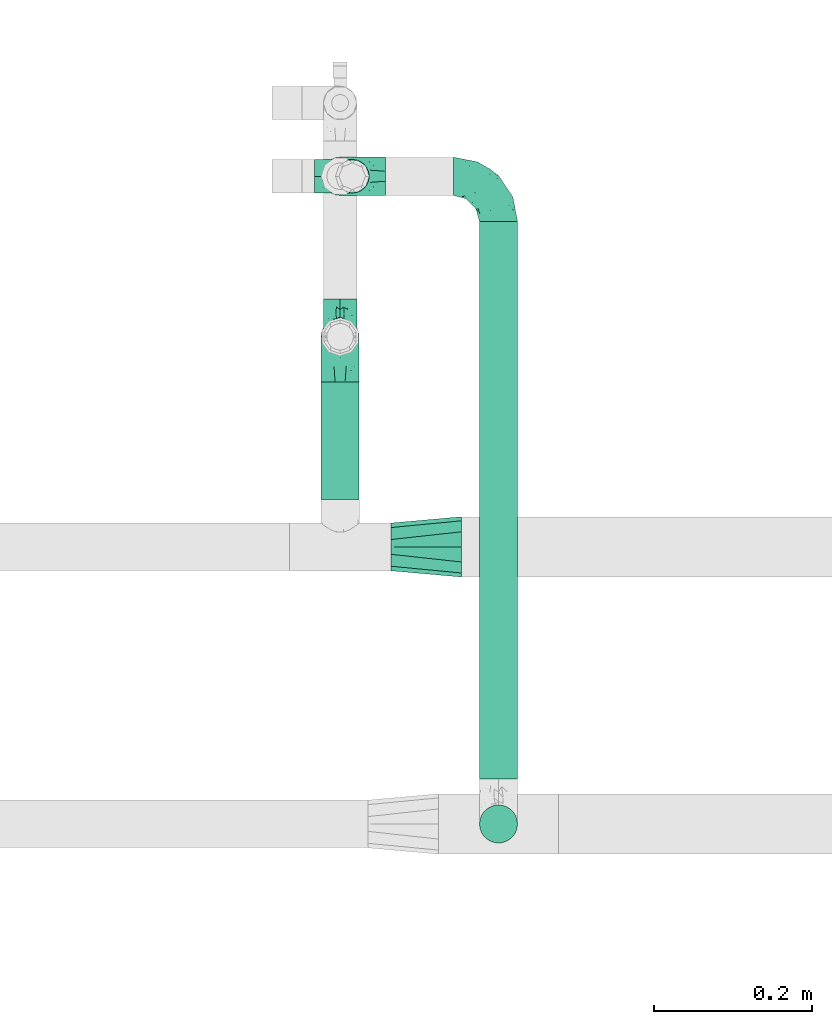
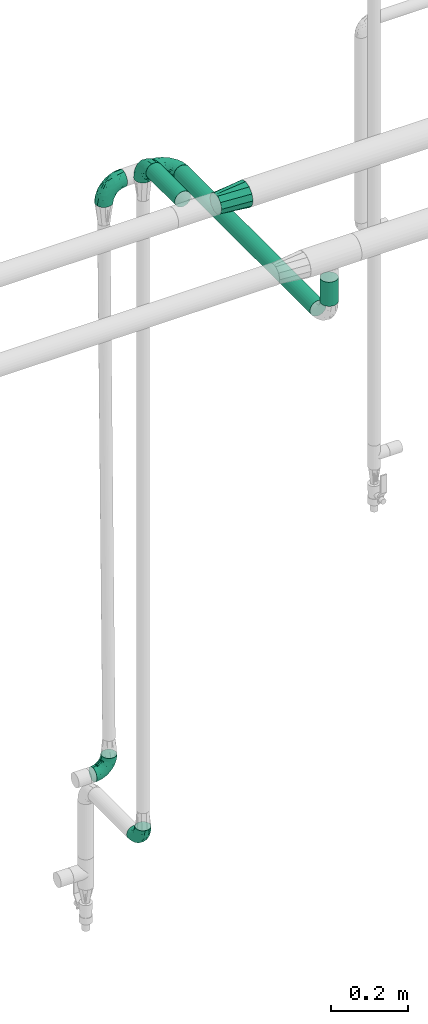
# One storey, part 565 of 824: 6 flow fittings, 3 flow segments.
"""IFC2X3 building model written with IfcOpenShell, lengths in millimetres."""

from ifc_helpers import new_model, entity, si_unit, converted_unit, derived_unit, direction, frame, origin, origin_2d_with_axis, place, context, subcontext, project, spatial, circle, extrude, faceted_brep, source, transform, mapped, material, type_object, type_shapes, element, save


model = new_model("IFC2X3")

# Units and contexts
model_context = context("Model", 3, precision=0.01, world=origin(), true_north=direction((6.12303176911189e-17, 1.0)))
body_context = subcontext(model_context, "Body", "Model", "MODEL_VIEW")
ifc_project = project(units=[si_unit("LENGTHUNIT", "METRE", prefix="MILLI"), si_unit("AREAUNIT", "SQUARE_METRE"), si_unit("VOLUMEUNIT", "CUBIC_METRE"), converted_unit("PLANEANGLEUNIT", "DEGREE", entity("IfcRatioMeasure", 0.0174532925199433), si_unit("PLANEANGLEUNIT", "RADIAN"), dimensions=[0, 0, 0, 0, 0, 0, 0]), si_unit("MASSUNIT", "GRAM", prefix="KILO"), derived_unit("MASSDENSITYUNIT", [(si_unit("MASSUNIT", "GRAM", prefix="KILO"), 1), (si_unit("LENGTHUNIT", "METRE"), -3)]), derived_unit("MOMENTOFINERTIAUNIT", [(si_unit("LENGTHUNIT", "METRE"), 4)]), si_unit("TIMEUNIT", "SECOND"), si_unit("FREQUENCYUNIT", "HERTZ"), si_unit("THERMODYNAMICTEMPERATUREUNIT", "DEGREE_CELSIUS"), derived_unit("THERMALTRANSMITTANCEUNIT", [(si_unit("MASSUNIT", "GRAM", prefix="KILO"), 1), (si_unit("THERMODYNAMICTEMPERATUREUNIT", "KELVIN"), -1), (si_unit("TIMEUNIT", "SECOND"), -3)]), derived_unit("VOLUMETRICFLOWRATEUNIT", [(si_unit("LENGTHUNIT", "METRE"), 3), (si_unit("TIMEUNIT", "SECOND"), -1)]), derived_unit("MASSFLOWRATEUNIT", [(si_unit("MASSUNIT", "GRAM", prefix="KILO"), 1), (si_unit("TIMEUNIT", "SECOND"), -1)]), derived_unit("ROTATIONALFREQUENCYUNIT", [(si_unit("TIMEUNIT", "SECOND"), -1)]), si_unit("ELECTRICCURRENTUNIT", "AMPERE"), si_unit("ELECTRICVOLTAGEUNIT", "VOLT"), si_unit("POWERUNIT", "WATT"), si_unit("FORCEUNIT", "NEWTON", prefix="KILO"), si_unit("ILLUMINANCEUNIT", "LUX"), si_unit("LUMINOUSFLUXUNIT", "LUMEN"), si_unit("LUMINOUSINTENSITYUNIT", "CANDELA"), derived_unit("USERDEFINED", [(si_unit("MASSUNIT", "GRAM", prefix="KILO"), -1), (si_unit("LENGTHUNIT", "METRE"), -2), (si_unit("TIMEUNIT", "SECOND"), 3), (si_unit("LUMINOUSFLUXUNIT", "LUMEN"), 1)]), derived_unit("LINEARVELOCITYUNIT", [(si_unit("LENGTHUNIT", "METRE"), 1), (si_unit("TIMEUNIT", "SECOND"), -1)]), si_unit("PRESSUREUNIT", "PASCAL"), derived_unit("USERDEFINED", [(si_unit("LENGTHUNIT", "METRE"), -2), (si_unit("MASSUNIT", "GRAM", prefix="KILO"), 1), (si_unit("TIMEUNIT", "SECOND"), -2)]), derived_unit("LINEARFORCEUNIT", [(si_unit("MASSUNIT", "GRAM", prefix="KILO"), 1), (si_unit("LENGTHUNIT", "METRE"), 1), (si_unit("TIMEUNIT", "SECOND"), -2), (si_unit("LENGTHUNIT", "METRE"), -1)]), derived_unit("PLANARFORCEUNIT", [(si_unit("MASSUNIT", "GRAM", prefix="KILO"), 1), (si_unit("LENGTHUNIT", "METRE"), 1), (si_unit("TIMEUNIT", "SECOND"), -2), (si_unit("LENGTHUNIT", "METRE"), -2)])], contexts=[model_context])

# Site, building, storey
site_placement = place(None, origin())
site = spatial("IfcSite", under=ifc_project, at=site_placement, CompositionType="ELEMENT")
building_placement = place(site_placement, origin())
building = spatial("IfcBuilding", under=site, at=building_placement, CompositionType="ELEMENT")
storey_placement = place(building_placement, frame((0.0, 0.0, 28200.0)))
storey = spatial("IfcBuildingStorey", under=building, at=storey_placement, CompositionType="ELEMENT", Elevation=28200.0)

# Flow segments
pipe_segment_type = type_object("IfcPipeSegmentType", PredefinedType="NOTDEFINED")
flow_segment_1_placement = place(storey_placement, frame((13430.37, 14809.89, 2774.4)))
element("IfcFlowSegment", 1, at=flow_segment_1_placement, inside=storey, type_object=pipe_segment_type, context=body_context, shape_type="SweptSolid", body=[
    extrude(circle(Radius=24.0, at=origin_2d_with_axis()), frame((25.6, 0.0, 25.6), z_axis=(0.0, 1.0, 0.0), x_axis=(1.0, 0.0, 0.0)), (0.0, 0.0, 1.0), 148.314300623279),
])
flow_segment_2_placement = place(storey_placement, frame((13630.36, 14457.0, 2574.4)))
element("IfcFlowSegment", 2, at=flow_segment_2_placement, inside=storey, type_object=pipe_segment_type, context=body_context, shape_type="SweptSolid", body=[
    extrude(circle(Radius=24.0, at=origin_2d_with_axis()), frame((25.6, 0.0, 25.61), z_axis=(0.0, 1.0, -2.41535411879e-05), x_axis=(-1.0, 0.0, 0.0)), (0.0, 0.0, 1.0), 703.896986835568),
])
flow_segment_3_placement = place(storey_placement, frame((13630.36, 14374.4, 2657.01)))
element("IfcFlowSegment", 3, at=flow_segment_3_placement, inside=storey, type_object=pipe_segment_type, context=body_context, shape_type="SweptSolid", body=[
    extrude(circle(Radius=24.0, at=origin_2d_with_axis()), frame((25.6, 25.6, 0.0)), (0.0, 0.0, 1.0), 75.9503658345094),
])

# Flow fittings
ifc_material = material()
pipe_fitting_type_1 = type_object("IfcPipeFittingType", PredefinedType="NOTDEFINED", material=ifc_material)
shared_shape_1 = source(origin(), body_context, "Body", "Brep", [
    faceted_brep([(-57.0, 12.07, -20.91), (-57.0, 6.25, -23.33), (-57.0, 0.0, -24.15), (-57.0, -6.25, -23.33), (-57.0, -12.08, -20.91), (-57.0, -17.08, -17.08), (-57.0, -20.91, -12.08), (-57.0, -23.33, -6.25), (-57.0, -24.15, 0.0), (-57.0, -23.33, 6.25), (-57.0, -20.91, 12.07), (-57.0, -17.08, 17.08), (-57.0, -12.08, 20.91), (-57.0, -6.25, 23.33), (-57.0, 0.0, 24.15), (-57.0, 6.25, 23.33), (-57.0, 12.07, 20.91), (-57.0, 17.08, 17.08), (-57.0, 20.91, 12.07), (-57.0, 23.33, 6.25), (-57.0, 24.15, 0.0), (-57.0, 23.33, -6.25), (-57.0, 20.91, -12.08), (-57.0, 17.08, -17.08), (0.0, 57.0, -24.15), (-6.25, 57.0, -23.33), (-12.07, 57.0, -20.91), (-17.08, 57.0, -17.08), (-20.91, 57.0, -12.08), (-23.33, 57.0, -6.25), (-24.15, 57.0, 0.0), (-23.33, 57.0, 6.25), (-20.91, 57.0, 12.07), (-17.08, 57.0, 17.08), (-12.07, 57.0, 20.91), (-6.25, 57.0, 23.33), (0.0, 57.0, 24.15), (6.25, 57.0, 23.33), (12.08, 57.0, 20.91), (17.08, 57.0, 17.08), (20.91, 57.0, 12.07), (23.33, 57.0, 6.25), (24.15, 57.0, 0.0), (23.33, 57.0, -6.25), (20.91, 57.0, -12.08), (17.08, 57.0, -17.08), (12.08, 57.0, -20.91), (6.25, 57.0, -23.33), (14.9, 21.14, 6.17), (13.61, 24.64, 12.48), (6.23, 8.95, 8.98), (-41.47, -21.06, 0.0), (-41.92, -18.38, 13.72), (-24.64, -13.61, 12.48), (-37.37, -13.24, 18.15), (-6.8, -4.93, 8.18), (-21.76, -15.19, 6.22), (-12.78, -9.18, 0.0), (-37.73, -20.51, 7.75), (-7.38, 7.38, 20.24), (-23.37, -4.26, 20.42), (-11.9, -3.19, 15.86), (-42.14, -8.7, 21.82), (13.24, 37.37, 18.15), (9.33, 23.53, 16.85), (4.26, 23.37, 20.42), (2.77, 10.92, 15.55), (-29.46, 0.91, 23.52), (-44.13, 20.56, 15.69), (-39.25, 26.33, 10.88), (-49.02, 22.92, 9.96), (-34.58, 23.87, 17.15), (-15.8, 6.8, 22.81), (-8.67, 20.47, 23.88), (-18.12, 12.9, 24.08), (-48.29, 14.92, 19.65), (-44.06, -2.85, 23.78), (-9.23, 48.95, 22.58), (-3.78, 42.74, 24.07), (-40.34, 4.26, 24.09), (-44.02, 26.14, 5.46), (-44.04, 9.88, 22.74), (-4.95, 16.87, 22.52), (-2.75, 1.43, 12.5), (-25.48, 40.98, 10.71), (20.51, 37.73, 7.75), (18.38, 41.92, 13.72), (8.7, 42.14, 21.82), (-25.95, -17.97, 0.0), (2.85, 44.06, 23.78), (21.06, 41.47, 0.0), (17.97, 25.95, 0.0), (-24.04, -9.27, 17.13), (-33.26, 33.26, 5.86), (-28.55, 40.57, 0.0), (-40.57, 28.55, 0.0), (-25.29, 47.19, 4.06), (-27.01, 31.1, 16.77), (-15.7, 43.95, 19.9), (-20.27, 45.22, 15.61), (-30.53, 31.98, 12.64), (-11.28, 38.33, 22.92), (-9.97, 27.88, 24.09), (-20.15, 30.26, 21.25), (-31.25, 11.75, 23.64), (-28.75, 7.23, 24.15), (-29.53, 18.06, 22.27), (-28.44, 24.21, 20.02), (-37.55, 17.7, 20.26), (-15.88, 29.25, 22.99), (-20.82, 20.82, 23.44), (-0.91, 29.46, 23.52), (-13.5, -7.67, 12.04), (1.49, 1.56, 5.16), (8.86, 10.35, 4.59), (0.38, -0.38, 0.0), (9.18, 12.78, 0.0), (-37.37, -13.24, -18.15), (8.86, 10.35, -4.59), (-45.22, 20.27, -15.61), (-43.95, 15.7, -19.9), (-38.33, 11.28, -22.92), (-48.95, 9.23, -22.58), (-47.19, 25.29, -4.06), (-33.26, 33.26, -5.86), (18.38, 41.92, -13.72), (-30.26, 20.15, -21.25), (2.85, 44.06, -23.78), (-4.26, 40.34, -24.09), (-40.98, 25.48, -10.71), (-41.92, -18.38, -13.72), (9.25, 23.5, -16.92), (4.26, 23.37, -20.42), (13.24, 37.37, -18.15), (-37.73, -20.51, -7.75), (-11.75, 31.25, -23.64), (-7.23, 28.75, -24.15), (-12.9, 18.12, -24.08), (8.7, 42.14, -21.82), (-44.06, -2.85, -23.78), (-6.8, 15.8, -22.81), (-20.47, 8.67, -23.88), (-24.64, -13.61, -12.48), (-42.74, 3.78, -24.07), (-18.06, 29.53, -22.27), (-24.21, 28.44, -20.02), (-27.88, 9.97, -24.09), (-31.1, 27.01, -16.77), (-26.14, 44.02, -5.46), (14.9, 21.14, -6.17), (20.51, 37.73, -7.75), (-9.88, 44.04, -22.74), (-20.56, 44.13, -15.69), (-21.76, -15.19, -6.22), (-13.5, -7.67, -12.04), (-24.14, -9.76, -16.74), (-11.9, -3.19, -15.86), (-14.92, 48.29, -19.65), (-23.37, -4.26, -20.42), (-0.91, 29.46, -23.52), (-26.33, 39.25, -10.88), (-23.87, 34.58, -17.15), (-42.14, -8.7, -21.82), (-22.92, 49.02, -9.96), (13.61, 24.64, -12.48), (-31.98, 30.53, -12.64), (-16.87, 4.95, -22.52), (-17.7, 37.55, -20.26), (-29.25, 15.88, -22.99), (-20.82, 20.82, -23.44), (-29.46, 0.91, -23.52), (-7.38, 7.38, -20.24), (2.77, 10.92, -15.55), (6.23, 8.95, -8.98), (-6.8, -4.93, -8.18), (-2.81, 1.41, -12.54), (1.49, 1.56, -5.16)], [[[0, 1, 2, 3, 4, 5, 6, 7, 8, 9, 10, 11, 12, 13, 14, 15, 16, 17, 18, 19, 20, 21, 22, 23]], [[24, 25, 26, 27, 28, 29, 30, 31, 32, 33, 34, 35, 36, 37, 38, 39, 40, 41, 42, 43, 44, 45, 46, 47]], [[48, 49, 50]], [[9, 8, 51]], [[52, 53, 54]], [[55, 56, 57]], [[10, 58, 52]], [[9, 58, 10]], [[59, 60, 61]], [[54, 12, 11]], [[54, 62, 12]], [[63, 39, 38]], [[64, 65, 66]], [[62, 60, 67]], [[68, 69, 70]], [[71, 69, 68]], [[72, 73, 74]], [[16, 75, 17]], [[13, 76, 14]], [[35, 77, 78]], [[14, 79, 15]], [[17, 68, 18]], [[14, 76, 79]], [[20, 19, 80]], [[70, 19, 18]], [[81, 15, 79]], [[15, 81, 16]], [[73, 72, 82]], [[66, 83, 50]], [[32, 31, 84]], [[85, 86, 49]], [[63, 87, 65]], [[56, 58, 88]], [[36, 89, 37]], [[85, 41, 40]], [[36, 35, 78]], [[90, 41, 85]], [[40, 39, 86]], [[12, 62, 13]], [[86, 85, 40]], [[48, 85, 49]], [[85, 91, 90]], [[87, 38, 37]], [[92, 60, 54]], [[80, 69, 93]], [[93, 94, 95]], [[10, 52, 11]], [[94, 96, 30]], [[97, 98, 99]], [[80, 93, 95]], [[100, 97, 84]], [[99, 98, 33]], [[101, 102, 78]], [[103, 101, 98]], [[96, 31, 30]], [[77, 98, 101]], [[77, 35, 34]], [[34, 33, 98]], [[9, 51, 58]], [[87, 63, 38]], [[104, 105, 74]], [[106, 103, 107]], [[106, 81, 104]], [[75, 68, 17]], [[108, 107, 71]], [[33, 32, 99]], [[109, 103, 110]], [[101, 109, 102]], [[89, 78, 111]], [[53, 52, 58]], [[54, 11, 52]], [[60, 62, 54]], [[88, 58, 51]], [[76, 62, 67]], [[53, 112, 92]], [[60, 59, 72]], [[39, 63, 86]], [[49, 86, 63]], [[89, 87, 37]], [[42, 41, 90]], [[111, 82, 65]], [[111, 65, 87]], [[65, 59, 66]], [[104, 81, 79]], [[75, 81, 108]], [[32, 84, 99]], [[97, 99, 84]], [[98, 97, 103]], [[106, 107, 108]], [[74, 102, 110]], [[111, 78, 102]], [[74, 110, 104]], [[74, 67, 72]], [[61, 92, 112]], [[66, 59, 61]], [[56, 53, 58]], [[66, 50, 49]], [[61, 112, 83]], [[66, 49, 64]], [[78, 89, 36]], [[87, 89, 111]], [[62, 76, 13]], [[79, 76, 67]], [[100, 93, 69]], [[96, 93, 84]], [[55, 113, 50]], [[113, 114, 50]], [[104, 79, 105]], [[106, 104, 110]], [[20, 80, 95]], [[85, 48, 91]], [[115, 114, 113]], [[116, 91, 48]], [[70, 80, 19]], [[93, 96, 94]], [[84, 31, 96]], [[103, 106, 110]], [[81, 106, 108]], [[103, 97, 107]], [[71, 107, 97]], [[71, 97, 100]], [[108, 71, 68]], [[79, 67, 105]], [[67, 74, 105]], [[115, 113, 57]], [[112, 56, 55]], [[56, 88, 57]], [[60, 72, 67]], [[82, 72, 59]], [[65, 82, 59]], [[82, 111, 73]], [[111, 102, 73]], [[102, 74, 73]], [[81, 75, 16]], [[68, 75, 108]], [[68, 70, 18]], [[80, 70, 69]], [[98, 77, 34]], [[78, 77, 101]], [[93, 100, 84]], [[71, 100, 69]], [[102, 109, 110]], [[101, 103, 109]], [[53, 92, 54]], [[61, 60, 92]], [[56, 112, 53]], [[83, 112, 55]], [[50, 83, 55]], [[61, 83, 66]], [[49, 63, 64]], [[65, 64, 63]], [[57, 113, 55]], [[114, 115, 116]], [[116, 48, 114]], [[48, 50, 114]], [[117, 5, 4]], [[116, 115, 118]], [[119, 120, 23]], [[121, 122, 120]], [[95, 123, 20]], [[0, 23, 120]], [[124, 95, 94]], [[125, 45, 44]], [[121, 120, 126]], [[24, 127, 128]], [[22, 21, 129]], [[0, 122, 1]], [[5, 117, 130]], [[131, 132, 133]], [[134, 88, 51]], [[135, 136, 137]], [[6, 5, 130]], [[46, 138, 47]], [[139, 3, 2]], [[140, 141, 137]], [[6, 134, 7]], [[134, 130, 142]], [[143, 2, 1]], [[144, 126, 145]], [[121, 146, 143]], [[147, 120, 119]], [[94, 148, 124]], [[149, 150, 91]], [[30, 29, 148]], [[151, 25, 128]], [[27, 152, 28]], [[134, 153, 88]], [[154, 155, 156]], [[27, 26, 157]], [[151, 26, 25]], [[155, 158, 156]], [[24, 47, 127]], [[1, 122, 143]], [[138, 132, 159]], [[160, 152, 161]], [[24, 128, 25]], [[46, 133, 138]], [[162, 117, 4]], [[148, 160, 124]], [[152, 160, 163]], [[154, 142, 155]], [[45, 125, 133]], [[133, 46, 45]], [[125, 164, 133]], [[51, 7, 134]], [[42, 90, 43]], [[165, 147, 129]], [[153, 134, 142]], [[43, 150, 44]], [[162, 4, 3]], [[141, 140, 166]], [[117, 162, 158]], [[163, 29, 28]], [[43, 90, 150]], [[123, 21, 20]], [[144, 151, 135]], [[157, 152, 27]], [[167, 145, 161]], [[23, 22, 119]], [[168, 126, 169]], [[121, 168, 146]], [[139, 143, 170]], [[142, 130, 117]], [[8, 7, 51]], [[134, 6, 130]], [[139, 162, 3]], [[170, 166, 158]], [[170, 158, 162]], [[158, 171, 156]], [[44, 150, 125]], [[91, 150, 90]], [[164, 125, 150]], [[132, 138, 133]], [[127, 138, 159]], [[131, 164, 172]], [[132, 171, 140]], [[135, 151, 128]], [[157, 151, 167]], [[22, 129, 119]], [[147, 119, 129]], [[120, 147, 126]], [[144, 145, 167]], [[137, 146, 169]], [[170, 143, 146]], [[137, 169, 135]], [[137, 159, 140]], [[171, 172, 156]], [[173, 174, 175]], [[156, 175, 154]], [[174, 57, 153]], [[132, 172, 171]], [[172, 164, 173]], [[143, 139, 2]], [[162, 139, 170]], [[138, 127, 47]], [[128, 127, 159]], [[165, 124, 160]], [[123, 124, 129]], [[149, 173, 164]], [[176, 174, 173]], [[135, 128, 136]], [[144, 135, 169]], [[150, 149, 164]], [[176, 118, 115]], [[149, 91, 116]], [[30, 148, 94]], [[163, 148, 29]], [[124, 123, 95]], [[129, 21, 123]], [[126, 144, 169]], [[151, 144, 167]], [[126, 147, 145]], [[161, 145, 147]], [[161, 147, 165]], [[167, 161, 152]], [[128, 159, 136]], [[159, 137, 136]], [[154, 153, 142]], [[132, 140, 159]], [[174, 176, 57]], [[57, 88, 153]], [[166, 140, 171]], [[158, 166, 171]], [[166, 170, 141]], [[170, 146, 141]], [[146, 137, 141]], [[151, 157, 26]], [[152, 157, 167]], [[152, 163, 28]], [[148, 163, 160]], [[120, 122, 0]], [[143, 122, 121]], [[124, 165, 129]], [[161, 165, 160]], [[146, 168, 169]], [[121, 126, 168]], [[142, 117, 155]], [[158, 155, 117]], [[175, 156, 172]], [[153, 154, 174]], [[173, 175, 172]], [[174, 154, 175]], [[164, 131, 133]], [[172, 132, 131]], [[176, 173, 118]], [[57, 176, 115]], [[173, 149, 118]], [[149, 116, 118]]]),
])
type_shapes(pipe_fitting_type_1, [shared_shape_1])
for number, where, z_axis, x_axis in (
    (4, (13455.97, 15217.9, 2600.0), (0.0, 1.0, 0.0), (0.0, 0.0, 1.0)),
    (5, (13655.95, 15217.9, 2600.0), (0.0, 0.0, 1.0), (0.0, 1.0, 0.0)),
    (6, (13455.97, 15015.21, 2800.0), (-1.0, 0.0, 0.0), (0.0, 1.0, 0.0)),
):
    element("IfcFlowFitting", number, at=place(storey_placement, frame(where, z_axis=z_axis, x_axis=x_axis)), inside=storey, type_object=pipe_fitting_type_1, material=ifc_material, context=body_context, shape_type="MappedRepresentation", body=[
        mapped(shared_shape_1, transform((0.0, 0.0, 0.0), scale=1.0)),
    ])
pipe_fitting_type_2 = type_object("IfcPipeFittingType", PredefinedType="NOTDEFINED", material=ifc_material)
shared_shape_2 = source(origin(), body_context, "Body", "Brep", [
    faceted_brep([(-48.0, 10.6, -18.36), (-48.0, 5.49, -20.48), (-48.0, 0.0, -21.2), (-48.0, -5.49, -20.48), (-48.0, -10.6, -18.36), (-48.0, -14.99, -14.99), (-48.0, -18.36, -10.6), (-48.0, -20.48, -5.49), (-48.0, -21.2, 0.0), (-48.0, -20.48, 5.49), (-48.0, -18.36, 10.6), (-48.0, -14.99, 14.99), (-48.0, -10.6, 18.36), (-48.0, -5.49, 20.48), (-48.0, 0.0, 21.2), (-48.0, 5.49, 20.48), (-48.0, 10.6, 18.36), (-48.0, 14.99, 14.99), (-48.0, 18.36, 10.6), (-48.0, 20.48, 5.49), (-48.0, 21.2, 0.0), (-48.0, 20.48, -5.49), (-48.0, 18.36, -10.6), (-48.0, 14.99, -14.99), (0.0, 48.0, -21.2), (-5.49, 48.0, -20.48), (-10.6, 48.0, -18.36), (-14.99, 48.0, -14.99), (-18.36, 48.0, -10.6), (-20.48, 48.0, -5.49), (-21.2, 48.0, 0.0), (-20.48, 48.0, 5.49), (-18.36, 48.0, 10.6), (-14.99, 48.0, 14.99), (-10.6, 48.0, 18.36), (-5.49, 48.0, 20.48), (0.0, 48.0, 21.2), (5.49, 48.0, 20.48), (10.6, 48.0, 18.36), (14.99, 48.0, 14.99), (18.36, 48.0, 10.6), (20.48, 48.0, 5.49), (21.2, 48.0, 0.0), (20.48, 48.0, -5.49), (18.36, 48.0, -10.6), (14.99, 48.0, -14.99), (10.6, 48.0, -18.36), (5.49, 48.0, -20.48), (-35.25, -16.22, 12.01), (-34.76, -18.57, 0.0), (-20.87, -12.37, 10.9), (-31.49, -11.78, 15.9), (-37.0, -2.58, 20.86), (-33.89, 3.62, 21.15), (-31.81, -18.14, 6.76), (-5.78, 5.78, 17.67), (-19.42, -4.1, 17.86), (-9.6, -3.39, 13.73), (-35.44, -7.73, 19.13), (11.78, 31.49, 15.9), (-5.93, -5.46, 6.95), (-18.45, -13.78, 5.46), (-10.29, -8.43, 0.0), (-24.6, 0.55, 20.62), (-37.28, 17.94, 13.81), (-33.38, 22.85, 9.59), (-41.46, 20.06, 8.75), (-29.51, 20.45, 15.16), (-15.04, 10.79, 21.13), (-7.08, 16.98, 20.93), (-8.39, 23.51, 21.15), (-40.86, 13.03, 17.26), (-8.05, 41.26, 19.83), (-3.21, 35.97, 21.14), (8.53, 19.66, 14.74), (4.1, 19.42, 17.86), (-37.72, 22.66, 4.78), (-37.07, 8.58, 19.98), (-13.0, 5.43, 19.97), (-3.78, 13.93, 19.7), (3.02, 8.69, 13.43), (-2.27, -0.05, 10.65), (6.22, 6.99, 7.09), (-22.25, 34.6, 9.45), (18.14, 31.81, 6.76), (16.22, 35.25, 12.01), (12.37, 20.87, 10.9), (7.73, 35.44, 19.13), (-21.52, -15.93, 0.0), (2.58, 37.0, 20.86), (18.57, 34.76, 0.0), (13.78, 18.45, 5.46), (15.93, 21.52, 0.0), (-20.03, -8.54, 14.9), (-28.6, 28.6, 5.16), (-24.79, 34.6, 0.0), (-34.6, 24.79, 0.0), (-22.81, 37.41, 4.68), (-23.36, 26.33, 14.79), (-13.68, 37.05, 17.49), (-17.72, 38.12, 13.73), (-26.25, 27.3, 11.24), (-9.71, 32.34, 20.14), (-17.26, 25.6, 18.71), (-26.33, 9.99, 20.77), (-24.06, 6.05, 21.2), (-25.02, 15.46, 19.56), (-24.3, 20.72, 17.57), (-31.95, 15.23, 17.8), (-13.53, 24.7, 20.21), (-17.6, 17.6, 20.6), (-0.55, 24.6, 20.62), (-11.41, -7.48, 10.43), (0.93, -0.93, 0.0), (8.43, 10.29, 0.0), (-11.41, -7.48, -10.43), (-20.1, -8.84, -14.66), (-9.6, -3.39, -13.73), (7.73, 35.44, -19.13), (4.1, 19.42, -17.86), (-0.55, 24.6, -20.62), (-38.12, 17.72, -13.73), (-37.05, 13.68, -17.49), (-32.34, 9.71, -20.14), (-41.26, 8.05, -19.83), (-37.41, 22.81, -4.68), (-23.51, 8.39, -21.15), (-35.97, 3.21, -21.14), (-28.6, 28.6, -5.16), (-31.81, -18.14, -6.76), (-18.45, -13.78, -5.46), (-25.6, 17.26, -18.71), (-19.42, -4.1, -17.86), (-17.94, 37.28, -13.81), (-22.85, 33.38, -9.59), (-20.06, 41.46, -8.75), (-31.49, -11.78, -15.9), (-35.25, -16.22, -12.01), (8.53, 19.66, -14.74), (11.78, 31.49, -15.9), (-9.99, 26.33, -20.77), (-6.05, 24.06, -21.2), (-10.79, 15.04, -21.13), (-37.0, -2.58, -20.86), (-16.98, 7.08, -20.93), (-5.43, 13.0, -19.97), (-13.93, 3.78, -19.7), (-20.87, -12.37, -10.9), (-26.33, 23.36, -14.79), (-22.66, 37.72, -4.78), (13.78, 18.45, -5.46), (18.14, 31.81, -6.76), (-15.46, 25.02, -19.56), (-20.72, 24.3, -17.57), (16.22, 35.25, -12.01), (-13.03, 40.86, -17.26), (-8.58, 37.07, -19.98), (2.58, 37.0, -20.86), (-3.62, 33.89, -21.15), (-34.6, 22.25, -9.45), (6.22, 6.99, -7.09), (-20.45, 29.51, -15.16), (-35.44, -7.73, -19.13), (12.37, 20.87, -10.9), (-27.3, 26.25, -11.24), (-15.23, 31.95, -17.8), (-24.7, 13.53, -20.21), (-24.6, 0.55, -20.62), (-5.78, 5.78, -17.67), (-17.6, 17.6, -20.6), (3.02, 8.69, -13.43), (-5.93, -5.46, -6.95), (-2.27, -0.05, -10.65)], [[[0, 1, 2, 3, 4, 5, 6, 7, 8, 9, 10, 11, 12, 13, 14, 15, 16, 17, 18, 19, 20, 21, 22, 23]], [[24, 25, 26, 27, 28, 29, 30, 31, 32, 33, 34, 35, 36, 37, 38, 39, 40, 41, 42, 43, 44, 45, 46, 47]], [[10, 48, 11]], [[9, 8, 49]], [[48, 50, 51]], [[14, 52, 53]], [[10, 54, 48]], [[9, 54, 10]], [[55, 56, 57]], [[51, 12, 11]], [[51, 58, 12]], [[59, 39, 38]], [[60, 61, 62]], [[58, 56, 63]], [[64, 65, 66]], [[67, 65, 64]], [[68, 69, 70]], [[16, 71, 17]], [[13, 52, 14]], [[35, 72, 73]], [[14, 53, 15]], [[17, 64, 18]], [[74, 59, 75]], [[20, 19, 76]], [[66, 19, 18]], [[77, 15, 53]], [[15, 77, 16]], [[69, 78, 79]], [[80, 81, 82]], [[32, 31, 83]], [[84, 85, 86]], [[59, 87, 75]], [[61, 54, 88]], [[36, 89, 37]], [[84, 41, 40]], [[36, 35, 73]], [[90, 41, 84]], [[40, 39, 85]], [[12, 58, 13]], [[85, 84, 40]], [[91, 84, 86]], [[84, 92, 90]], [[87, 38, 37]], [[93, 56, 51]], [[65, 94, 76]], [[94, 95, 96]], [[84, 91, 92]], [[95, 97, 30]], [[98, 99, 100]], [[76, 94, 96]], [[101, 98, 83]], [[100, 99, 33]], [[102, 70, 73]], [[103, 102, 99]], [[94, 97, 95]], [[72, 99, 102]], [[72, 35, 34]], [[34, 33, 99]], [[9, 49, 54]], [[87, 59, 38]], [[104, 105, 68]], [[106, 103, 107]], [[106, 77, 104]], [[71, 64, 17]], [[108, 107, 67]], [[33, 32, 100]], [[109, 103, 110]], [[102, 109, 70]], [[89, 73, 111]], [[50, 48, 54]], [[51, 11, 48]], [[56, 58, 51]], [[88, 54, 49]], [[52, 58, 63]], [[50, 112, 93]], [[56, 55, 78]], [[39, 59, 85]], [[86, 85, 59]], [[89, 87, 37]], [[42, 41, 90]], [[111, 79, 75]], [[111, 75, 87]], [[75, 55, 80]], [[104, 77, 53]], [[71, 77, 108]], [[32, 83, 100]], [[98, 100, 83]], [[99, 98, 103]], [[106, 107, 108]], [[68, 70, 110]], [[111, 73, 70]], [[68, 110, 104]], [[68, 63, 78]], [[57, 93, 112]], [[80, 55, 57]], [[61, 50, 54]], [[80, 82, 86]], [[81, 57, 112]], [[74, 86, 59]], [[60, 113, 82]], [[82, 114, 91]], [[101, 94, 65]], [[97, 94, 83]], [[73, 89, 36]], [[87, 89, 111]], [[58, 52, 13]], [[53, 52, 63]], [[104, 53, 105]], [[106, 104, 110]], [[20, 76, 96]], [[76, 19, 66]], [[103, 106, 110]], [[77, 106, 108]], [[103, 98, 107]], [[67, 107, 98]], [[67, 98, 101]], [[108, 67, 64]], [[53, 63, 105]], [[63, 68, 105]], [[83, 31, 97]], [[30, 97, 31]], [[62, 113, 60]], [[112, 61, 60]], [[61, 88, 62]], [[86, 82, 91]], [[56, 78, 63]], [[114, 82, 113]], [[114, 92, 91]], [[79, 78, 55]], [[75, 79, 55]], [[69, 79, 111]], [[70, 69, 111]], [[78, 69, 68]], [[77, 71, 16]], [[64, 71, 108]], [[64, 66, 18]], [[76, 66, 65]], [[99, 72, 34]], [[73, 72, 102]], [[94, 101, 83]], [[67, 101, 65]], [[75, 80, 74]], [[80, 86, 74]], [[70, 109, 110]], [[102, 103, 109]], [[50, 93, 51]], [[57, 56, 93]], [[61, 112, 50]], [[81, 112, 60]], [[82, 81, 60]], [[80, 57, 81]], [[115, 116, 117]], [[118, 119, 120]], [[121, 122, 23]], [[123, 124, 122]], [[96, 125, 20]], [[123, 126, 127]], [[128, 96, 95]], [[129, 130, 88]], [[123, 122, 131]], [[116, 132, 117]], [[133, 134, 135]], [[0, 124, 1]], [[5, 136, 137]], [[138, 119, 139]], [[129, 88, 49]], [[140, 141, 142]], [[6, 5, 137]], [[46, 118, 47]], [[143, 3, 2]], [[144, 145, 146]], [[6, 129, 7]], [[129, 137, 147]], [[127, 2, 1]], [[148, 122, 121]], [[128, 125, 96]], [[134, 128, 149]], [[95, 149, 128]], [[150, 151, 92]], [[30, 29, 149]], [[152, 131, 153]], [[27, 133, 28]], [[154, 45, 44]], [[136, 5, 4]], [[27, 26, 155]], [[156, 26, 25]], [[24, 157, 158]], [[24, 47, 157]], [[22, 21, 159]], [[160, 150, 114]], [[134, 133, 161]], [[142, 144, 126]], [[46, 139, 118]], [[162, 136, 4]], [[156, 25, 158]], [[1, 124, 127]], [[115, 147, 116]], [[45, 154, 139]], [[139, 46, 45]], [[154, 163, 139]], [[162, 4, 3]], [[42, 90, 43]], [[130, 129, 147]], [[49, 7, 129]], [[43, 151, 44]], [[0, 23, 122]], [[24, 158, 25]], [[136, 162, 132]], [[135, 29, 28]], [[43, 90, 151]], [[164, 148, 159]], [[152, 156, 140]], [[155, 133, 27]], [[165, 153, 161]], [[23, 22, 121]], [[123, 131, 166]], [[123, 166, 126]], [[143, 127, 167]], [[147, 137, 136]], [[8, 7, 49]], [[129, 6, 137]], [[143, 162, 3]], [[167, 146, 132]], [[167, 132, 162]], [[132, 168, 117]], [[44, 151, 154]], [[92, 151, 90]], [[163, 154, 151]], [[119, 118, 139]], [[157, 118, 120]], [[138, 139, 163]], [[119, 168, 145]], [[140, 156, 158]], [[155, 156, 165]], [[22, 159, 121]], [[148, 121, 159]], [[122, 148, 131]], [[152, 153, 165]], [[142, 126, 169]], [[167, 127, 126]], [[142, 169, 140]], [[142, 120, 145]], [[168, 170, 117]], [[160, 171, 172]], [[115, 172, 171]], [[171, 62, 130]], [[119, 170, 168]], [[170, 163, 160]], [[150, 163, 151]], [[113, 171, 160]], [[164, 128, 134]], [[125, 128, 159]], [[127, 143, 2]], [[162, 143, 167]], [[118, 157, 47]], [[158, 157, 120]], [[140, 158, 141]], [[152, 140, 169]], [[30, 149, 95]], [[149, 29, 135]], [[131, 152, 169]], [[156, 152, 165]], [[131, 148, 153]], [[161, 153, 148]], [[161, 148, 164]], [[165, 161, 133]], [[158, 120, 141]], [[120, 142, 141]], [[159, 21, 125]], [[20, 125, 21]], [[115, 130, 147]], [[114, 113, 160]], [[62, 171, 113]], [[62, 88, 130]], [[160, 163, 150]], [[150, 92, 114]], [[119, 145, 120]], [[146, 145, 168]], [[132, 146, 168]], [[144, 146, 167]], [[126, 144, 167]], [[145, 144, 142]], [[156, 155, 26]], [[133, 155, 165]], [[133, 135, 28]], [[149, 135, 134]], [[122, 124, 0]], [[127, 124, 123]], [[128, 164, 159]], [[161, 164, 134]], [[163, 170, 138]], [[170, 119, 138]], [[131, 169, 166]], [[126, 166, 169]], [[147, 136, 116]], [[132, 116, 136]], [[172, 115, 117]], [[130, 115, 171]], [[117, 170, 172]], [[160, 172, 170]]]),
])
type_shapes(pipe_fitting_type_2, [shared_shape_2])
for number, where, z_axis, x_axis in (
    (7, (13455.97, 15015.21, 650.0), (-1.0, 0.0, 0.0), (0.0, -1.0, 0.0)),
    (8, (13471.37, 15217.9, 750.0), (0.0, -1.0, 0.0), (1.0, 0.0, 0.0)),
):
    element("IfcFlowFitting", number, at=place(storey_placement, frame(where, z_axis=z_axis, x_axis=x_axis)), inside=storey, type_object=pipe_fitting_type_2, material=ifc_material, context=body_context, shape_type="MappedRepresentation", body=[
        mapped(shared_shape_2, transform((0.0, 0.0, 0.0), scale=1.0)),
    ])
pipe_fitting_type_3 = type_object("IfcPipeFittingType", PredefinedType="NOTDEFINED", material=ifc_material)
shared_shape_3 = source(origin(), body_context, "Body", "Brep", [
    faceted_brep([(89.0, 32.95, -19.02), (89.0, 36.11, -7.24), (89.0, 38.05, 0.0), (89.0, 36.11, 7.24), (89.0, 32.95, 19.03), (89.0, 25.99, 25.99), (89.0, 19.02, 32.95), (89.0, 9.51, 35.5), (89.0, 0.0, 38.05), (89.0, -9.51, 35.5), (89.0, -19.03, 32.95), (89.0, -25.99, 25.99), (89.0, -32.95, 19.03), (89.0, -36.11, 7.24), (89.0, -38.05, 0.0), (89.0, -36.11, -7.24), (89.0, -32.95, -19.02), (89.0, -25.99, -25.99), (89.0, -19.03, -32.95), (89.0, -9.51, -35.5), (89.0, 0.0, -38.05), (89.0, 9.51, -35.5), (89.0, 19.02, -32.95), (89.0, 25.99, -25.99), (0.0, 30.15, 0.0), (0.0, 27.27, -8.86), (0.0, 24.39, -17.72), (0.0, 16.85, -23.2), (0.0, 9.32, -28.67), (0.0, 0.0, -28.67), (0.0, -9.32, -28.67), (0.0, -16.85, -23.2), (0.0, -24.39, -17.72), (0.0, -27.27, -8.86), (0.0, -30.15, 0.0), (0.0, -27.27, 8.86), (0.0, -24.39, 17.72), (0.0, -16.85, 23.2), (0.0, -9.32, 28.67), (0.0, 0.0, 28.67), (0.0, 9.32, 28.67), (0.0, 16.85, 23.2), (0.0, 24.39, 17.72), (0.0, 27.27, 8.86)], [[[0, 1, 2, 3, 4, 5, 6, 7, 8, 9, 10, 11, 12, 13, 14, 15, 16, 17, 18, 19, 20, 21, 22, 23]], [[24, 25, 26, 27, 28, 29, 30, 31, 32, 33, 34, 35, 36, 37, 38, 39, 40, 41, 42, 43]], [[16, 33, 32]], [[28, 21, 29]], [[29, 19, 30]], [[19, 18, 30]], [[17, 32, 31]], [[34, 15, 14]], [[15, 34, 33]], [[22, 28, 27]], [[16, 15, 33]], [[0, 25, 1]], [[31, 30, 18]], [[1, 25, 24]], [[26, 0, 23]], [[24, 2, 1]], [[28, 22, 21]], [[16, 32, 17]], [[27, 26, 23]], [[26, 25, 0]], [[31, 18, 17]], [[22, 27, 23]], [[29, 21, 20]], [[19, 29, 20]], [[4, 43, 42]], [[38, 9, 39]], [[39, 7, 40]], [[7, 6, 40]], [[5, 42, 41]], [[24, 3, 2]], [[3, 24, 43]], [[10, 38, 37]], [[4, 3, 43]], [[12, 35, 13]], [[41, 40, 6]], [[13, 35, 34]], [[36, 12, 11]], [[34, 14, 13]], [[38, 10, 9]], [[4, 42, 5]], [[37, 36, 11]], [[36, 35, 12]], [[41, 6, 5]], [[10, 37, 11]], [[39, 9, 8]], [[7, 39, 8]]]),
])
type_shapes(pipe_fitting_type_3, [shared_shape_3])
flow_fitting_placement = place(storey_placement, frame((13519.97, 14749.89, 2800.0)))
element("IfcFlowFitting", 9, at=flow_fitting_placement, inside=storey, type_object=pipe_fitting_type_3, material=ifc_material, context=body_context, shape_type="MappedRepresentation", body=[
    mapped(shared_shape_3, transform((0.0, 0.0, 0.0), scale=1.0)),
])

save(model, "model.ifc")
